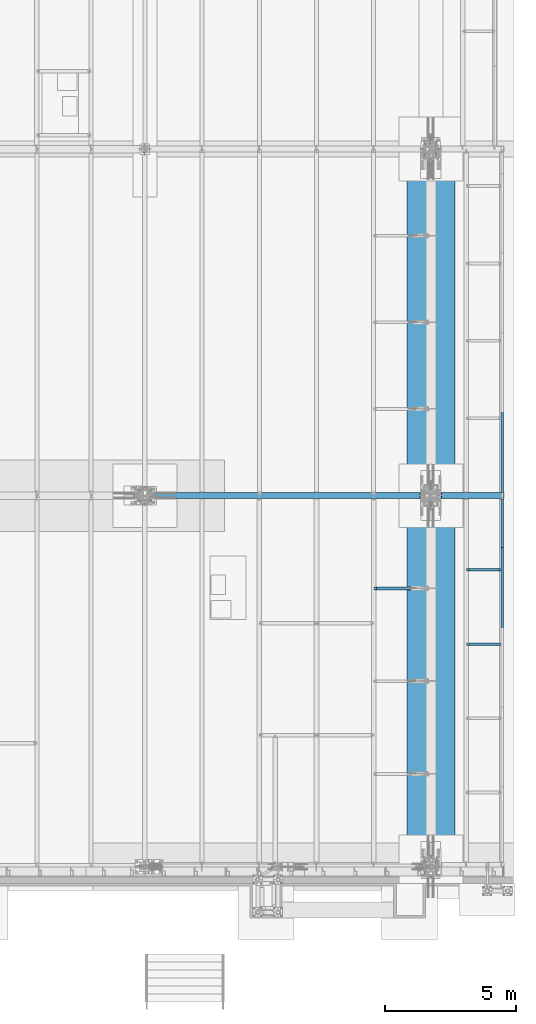
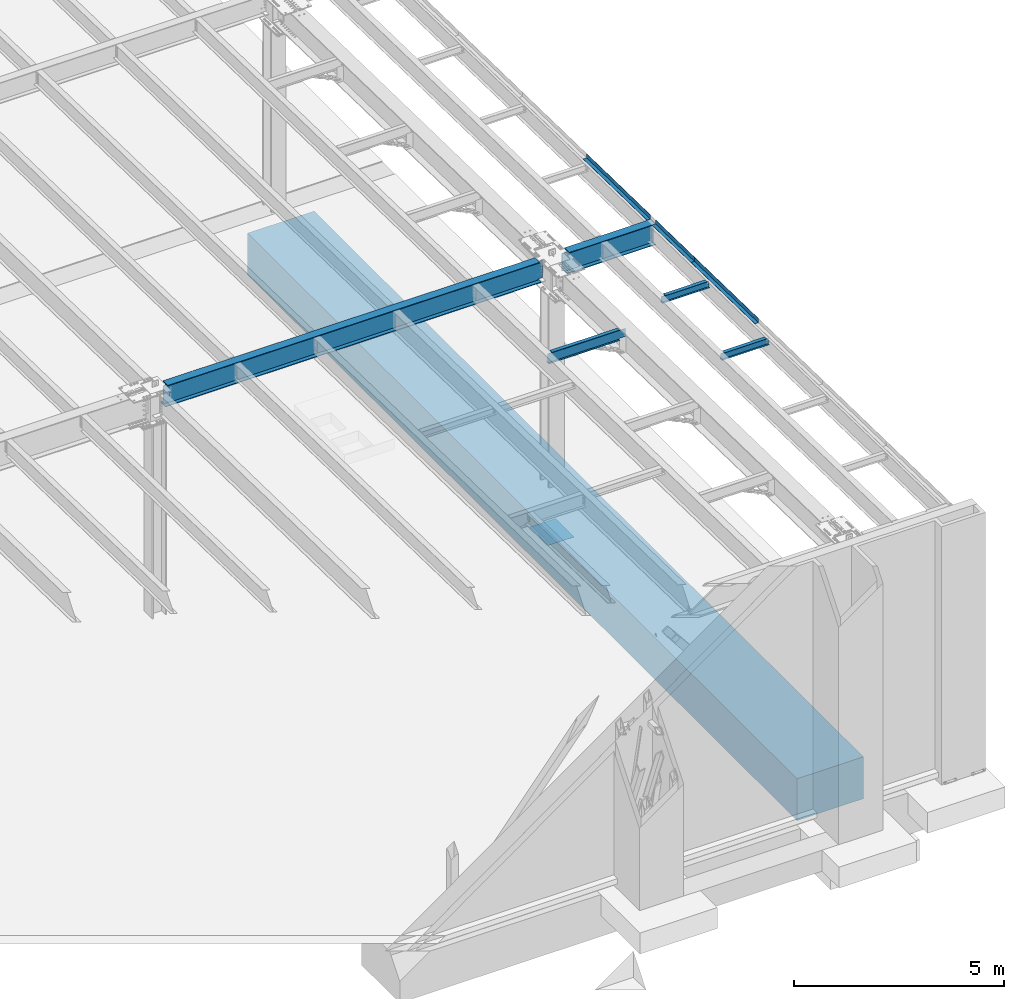
# One storey, part 1114 of 1763: 10 beams, 9 elements without a shape of their own.
"""IFC2X3 building model written with IfcOpenShell, lengths in millimetres."""

from ifc_helpers import new_model, si_unit, frame, origin_with_axes, place, context, subcontext, project, spatial, faceted_brep, material, type_object, element, aggregate, save


model = new_model("IFC2X3")

# Units and contexts
model_context = context("Model", 3, precision=1e-05, world=origin_with_axes())
body_context = subcontext(model_context, "Body", "Model", "MODEL_VIEW")
ifc_project = project(units=[si_unit("LENGTHUNIT", "METRE", prefix="MILLI"), si_unit("AREAUNIT", "SQUARE_METRE"), si_unit("VOLUMEUNIT", "CUBIC_METRE"), si_unit("MASSUNIT", "GRAM", prefix="KILO"), si_unit("TIMEUNIT", "SECOND"), si_unit("PLANEANGLEUNIT", "RADIAN"), si_unit("SOLIDANGLEUNIT", "STERADIAN"), si_unit("THERMODYNAMICTEMPERATUREUNIT", "DEGREE_CELSIUS"), si_unit("LUMINOUSINTENSITYUNIT", "LUMEN")], contexts=[model_context])

# Site, building, storey
site_placement = place(None, origin_with_axes())
site = spatial("IfcSite", under=ifc_project, at=site_placement, CompositionType="ELEMENT")
building_placement = place(site_placement, origin_with_axes())
building = spatial("IfcBuilding", under=site, at=building_placement, Name="Undefined", CompositionType="ELEMENT")
storey_placement = place(building_placement, origin_with_axes())
storey = spatial("IfcBuildingStorey", under=building, at=storey_placement, Name="Undefined", CompositionType="ELEMENT", Elevation=0.0)

# Assembly, beam
assembly_1_placement = place(storey_placement, origin_with_axes())
assembly_1 = element("IfcElementAssembly", 1, at=assembly_1_placement, inside=storey, Name="BEAM", AssemblyPlace="NOTDEFINED", PredefinedType="RIGID_FRAME")
ifc_material_1 = material(Name="STEEL/A36")
beam_type_1 = type_object("IfcBeamType", PredefinedType="NOTDEFINED")
beam_1_placement = place(assembly_1_placement, frame((-21348.1372736983, 2101.56926375685, 11877.1948079628), z_axis=(0.0, -0.999781542838788, 0.0209013539966307), x_axis=(1.0, 0.0, 0.0)))
beam_1 = element("IfcBeam", 2, at=beam_1_placement, type_object=beam_type_1, material=ifc_material_1, Name="BENT_PLATE", context=body_context, shape_type="Brep", body=[
    faceted_brep([(0.0, -3.17499999999927, -1523.99999999999), (0.0, -3.17499999999927, 1524.0), (0.0, 3.17499999999927, 1524.0), (0.0, 3.17499999999927, -1523.99999999999), (95.2499984741262, 3.17499999910251, 1523.99999999978), (95.2499984741262, 3.17500000090149, -1523.99999999977), (101.599998474125, -3.17499999909887, -1523.99999999978), (101.599999809252, -3.17500000000655, 1524.0), (95.2499984741262, 123.825003587437, 1523.99999999985), (95.2499984741262, 123.825003589236, -1523.9999999997), (101.599998474125, 123.825003587437, 1523.99999999985), (101.599998474125, 123.825003589236, -1523.9999999997)], [[[0, 1, 2, 3]], [[3, 2, 4, 5]], [[1, 0, 6, 7]], [[5, 4, 8, 9]], [[4, 2, 1, 7, 10, 8]], [[7, 6, 11, 10]], [[6, 0, 3, 5, 9, 11]], [[10, 11, 9, 8]]]),
])
aggregate(assembly_1, [beam_1])

# Assembly, beams
assembly_2_placement = place(storey_placement, origin_with_axes())
assembly_2 = element("IfcElementAssembly", 3, at=assembly_2_placement, inside=storey, Name="BEAM", AssemblyPlace="NOTDEFINED", PredefinedType="RIGID_FRAME")
beam_2_placement = place(assembly_2_placement, frame((-21348.1372736984, -595.183817089988, 11933.5729215789), z_axis=(0.0, -0.999781542838788, 0.0209013539966307), x_axis=(1.0, 0.0, 0.0)))
beam_2 = element("IfcBeam", 4, at=beam_2_placement, type_object=beam_type_1, material=ifc_material_1, Name="BENT_PLATE", context=body_context, shape_type="Brep", body=[
    faceted_brep([(7.71251507103443e-10, -3.17500000032305, -931.072000000008), (-6.47560227662325e-10, -3.17499999968095, 931.072000000008), (-7.71251507103443e-10, 3.17500000032487, 931.072000000008), (6.47560227662325e-10, 3.17499999968277, -931.072000000007), (95.2499984735041, 3.17500000219843, 931.07200000008), (95.2499984760543, 3.17500000155633, -931.071999999935), (101.599998476056, -3.1749999983258, -931.07199999993), (101.599998473506, -3.17499999768188, 931.072000000085), (95.2499984740389, 123.825003584232, 931.072000000157), (95.2499984755195, 123.825003584727, -931.071999999858), (101.599998474041, 123.82500358423, 931.072000000162), (101.599998475522, 123.825003584727, -931.071999999853)], [[[0, 1, 2, 3]], [[3, 2, 4, 5]], [[1, 0, 6, 7]], [[5, 4, 8, 9]], [[4, 2, 1, 7, 10, 8]], [[7, 6, 11, 10]], [[6, 0, 3, 5, 9, 11]], [[10, 11, 9, 8]]]),
])
beam_3_placement = place(assembly_2_placement, frame((-21348.1372736984, -3049.71948893012, 11984.887255447), z_axis=(0.0, -0.999781542838788, 0.0209013539966307), x_axis=(1.0, 0.0, 0.0)))
beam_3 = element("IfcBeam", 5, at=beam_3_placement, type_object=beam_type_1, material=ifc_material_1, Name="BENT_PLATE", context=body_context, shape_type="Brep", body=[
    faceted_brep([(0.0, -3.17499999999927, -1523.99999999999), (0.0, -3.17499999999927, 1524.0), (0.0, 3.17499999999927, 1524.0), (0.0, 3.17499999999927, -1523.99999999999), (95.2499984741262, 3.17499999910251, 1523.99999999978), (95.2499984741262, 3.17500000090149, -1523.99999999977), (101.599998474125, -3.17499999909887, -1523.99999999978), (101.599999809252, -3.17500000000655, 1524.0), (95.2499984741262, 123.825003587437, 1523.99999999985), (95.2499984741262, 123.825003589236, -1523.9999999997), (101.599998474125, 123.825003587437, 1523.99999999985), (101.599998474125, 123.825003589236, -1523.9999999997)], [[[0, 1, 2, 3]], [[3, 2, 4, 5]], [[1, 0, 6, 7]], [[5, 4, 8, 9]], [[4, 2, 1, 7, 10, 8]], [[7, 6, 11, 10]], [[6, 0, 3, 5, 9, 11]], [[10, 11, 9, 8]]]),
])
aggregate(assembly_2, [beam_2, beam_3])

# Assembly, beam
assembly_3_placement = place(storey_placement, origin_with_axes())
assembly_3 = element("IfcElementAssembly", 6, at=assembly_3_placement, inside=storey, Name="BEAM", AssemblyPlace="NOTDEFINED", PredefinedType="RIGID_FRAME")
ifc_material_2 = material(Name="STEEL/A992")
beam_type_2 = type_object("IfcBeamType", Name="W8X10", PredefinedType="NOTDEFINED")
beam_4_placement = place(assembly_3_placement, frame((-22678.4622736984, -5212.08, 11926.905204137), z_axis=(0.0, 0.0, 1.0), x_axis=(1.0, 0.0, 0.0)))
beam_4 = element("IfcBeam", 7, at=beam_4_placement, type_object=beam_type_2, material=ifc_material_2, Name="BEAM", ObjectType="W8X10", context=body_context, shape_type="Brep", body=[
    faceted_brep([(1249.3625, -50.7999999999993, 100.012500000001), (1249.3625, -50.7999999999993, 95.25), (1249.3625, -2.38125000000036, 95.25), (1249.3625, -2.38125000000036, 87.0525014841896), (1249.3625, 2.38125000000036, 87.0525014841896), (1249.3625, 2.38125000000036, 95.25), (1249.3625, 50.7999999999993, 95.25), (1249.3625, 50.7999999999993, 100.012500000001), (1250.32922992258, -2.38125000000036, 82.1924219661432), (1250.32922992258, 2.38125000000036, 82.1924219661432), (1253.08224382306, -2.38125000000036, 78.0722454979896), (1253.08224382306, 2.38125000000036, 78.0722454979896), (1257.20242029121, -2.38125000000036, 75.319231597512), (1257.20242029121, 2.38125000000036, 75.319231597512), (1262.06249980926, -2.38125000000036, 74.3525016749245), (1262.06249980926, 2.38125000000036, 74.3525016749245), (1331.91249999999, -2.38125000000036, 74.3525016749245), (1331.91249999999, 2.38125000000036, 74.3525016749245), (100.012500000012, -50.7999999999993, 100.012500000001), (100.012500000012, 50.7999999999993, 100.012500000001), (100.012500000012, 50.7999999999993, 95.25), (100.012500000012, 2.38124999999854, 95.25), (100.012499999993, 2.38125000000036, 87.0525014841896), (100.012499999993, -2.38125000000036, 87.0525014841896), (100.012500000012, -2.38124999999854, 95.25), (100.012500000012, -50.7999999999993, 95.25), (99.0457700774059, 2.38125000000036, 82.1924219661432), (99.0457700774059, -2.38125000000036, 82.1924219661432), (96.2927561769284, 2.38125000000036, 78.0722454979896), (96.2927561769284, -2.38125000000036, 78.0722454979896), (92.1725797087747, 2.38125000000036, 75.319231597512), (92.1725797087747, -2.38125000000036, 75.319231597512), (87.3125001907283, 2.38125000000036, 74.3525016749245), (87.3125001907283, -2.38125000000036, 74.3525016749245), (17.4624999999978, 2.38125000000036, 74.3525016749245), (17.4624999999978, -2.38125000000036, 74.3525016749245), (17.462499935149, 2.38124999999854, -95.25), (17.4625000000015, 50.7999999999993, -95.25), (17.4625000000015, 50.7999999999993, -100.012500000001), (17.4624996160601, -50.8000000000029, -100.012500000001), (17.4624996160601, -50.8000000000029, -95.25), (17.4624999065727, -2.38124999999854, -95.25), (1331.91249999999, 2.38125000000036, -95.25), (1331.91249999999, 50.7999999999993, -95.25), (1331.91249999999, 50.7999999999993, -100.012500000001), (1331.91249999999, -50.7999999999993, -100.012500000001), (1331.91249999999, -50.7999999999993, -95.25), (1331.91249999999, -2.38125000000036, -95.25)], [[[0, 1, 2, 3, 4, 5, 6, 7]], [[8, 9, 4, 3]], [[10, 11, 9, 8]], [[12, 13, 11, 10]], [[14, 15, 13, 12]], [[16, 17, 15, 14]], [[18, 19, 20, 21, 22, 23, 24, 25]], [[23, 22, 26, 27]], [[27, 26, 28, 29]], [[29, 28, 30, 31]], [[31, 30, 32, 33]], [[33, 32, 34, 35]], [[36, 37, 38, 39, 40, 41, 35, 34]], [[37, 36, 42, 43]], [[38, 37, 43, 44]], [[39, 38, 44, 45]], [[40, 39, 45, 46]], [[41, 40, 46, 47]], [[12, 10, 8, 3, 2, 24, 23, 27, 29, 31, 33, 35, 41, 47, 16, 14]], [[25, 24, 2, 1]], [[18, 25, 1, 0]], [[19, 18, 0, 7]], [[20, 19, 7, 6]], [[21, 20, 6, 5]], [[42, 36, 34, 32, 30, 28, 26, 22, 21, 5, 4, 9, 11, 13, 15, 17]], [[47, 46, 45, 44, 43, 42, 17, 16]]]),
])
aggregate(assembly_3, [beam_4])

assembly_4_placement = place(storey_placement, origin_with_axes())
assembly_4 = element("IfcElementAssembly", 8, at=assembly_4_placement, inside=storey, Name="BEAM", AssemblyPlace="NOTDEFINED", PredefinedType="RIGID_FRAME")
beam_5_placement = place(assembly_4_placement, frame((-22678.4622736984, -2377.44, 11867.6444384361), z_axis=(0.0, 0.0, 1.0), x_axis=(1.0, 0.0, 0.0)))
beam_5 = element("IfcBeam", 9, at=beam_5_placement, type_object=beam_type_2, material=ifc_material_2, Name="BEAM", ObjectType="W8X10", context=body_context, shape_type="Brep", body=[
    faceted_brep([(1249.3625, -50.7999999999993, 100.012500000001), (1249.3625, -50.7999999999993, 95.25), (1249.3625, -2.38125000000036, 95.25), (1249.3625, -2.38125000000036, 87.0525014841896), (1249.3625, 2.38125000000036, 87.0525014841896), (1249.3625, 2.38125000000036, 95.25), (1249.3625, 50.7999999999993, 95.25), (1249.3625, 50.7999999999993, 100.012500000001), (1250.32922992258, -2.38125000000036, 82.1924219661432), (1250.32922992258, 2.38125000000036, 82.1924219661432), (1253.08224382306, -2.38125000000036, 78.0722454979896), (1253.08224382306, 2.38125000000036, 78.0722454979896), (1257.20242029121, -2.38125000000036, 75.319231597512), (1257.20242029121, 2.38125000000036, 75.319231597512), (1262.06249980926, -2.38125000000036, 74.3525016749245), (1262.06249980926, 2.38125000000036, 74.3525016749245), (1331.91249999999, -2.38125000000036, 74.3525016749245), (1331.91249999999, 2.38125000000036, 74.3525016749245), (100.012500000012, -50.7999999999993, 100.012500000001), (100.012500000012, 50.7999999999993, 100.012500000001), (100.012500000012, 50.7999999999993, 95.25), (100.012500000012, 2.38124999999854, 95.25), (100.012499999993, 2.38125000000036, 87.0525014841896), (100.012499999993, -2.38125000000036, 87.0525014841896), (100.012500000012, -2.38124999999854, 95.25), (100.012500000012, -50.7999999999993, 95.25), (99.0457700774059, 2.38125000000036, 82.1924219661432), (99.0457700774059, -2.38125000000036, 82.1924219661432), (96.2927561769284, 2.38125000000036, 78.0722454979896), (96.2927561769284, -2.38125000000036, 78.0722454979896), (92.1725797087747, 2.38125000000036, 75.319231597512), (92.1725797087747, -2.38125000000036, 75.319231597512), (87.3125001907283, 2.38125000000036, 74.3525016749245), (87.3125001907283, -2.38125000000036, 74.3525016749245), (17.4624999999978, 2.38125000000036, 74.3525016749245), (17.4624999999978, -2.38125000000036, 74.3525016749245), (17.462499935149, 2.38124999999854, -95.25), (17.4625000000015, 50.7999999999993, -95.25), (17.4625000000015, 50.7999999999993, -100.012500000001), (17.4624996160601, -50.8000000000029, -100.012500000001), (17.4624996160601, -50.8000000000029, -95.25), (17.4624999065727, -2.38124999999854, -95.25), (1331.91249999999, 2.38125000000036, -95.25), (1331.91249999999, 50.7999999999993, -95.25), (1331.91249999999, 50.7999999999993, -100.012500000001), (1331.91249999999, -50.7999999999993, -100.012500000001), (1331.91249999999, -50.7999999999993, -95.25), (1331.91249999999, -2.38125000000036, -95.25)], [[[0, 1, 2, 3, 4, 5, 6, 7]], [[8, 9, 4, 3]], [[10, 11, 9, 8]], [[12, 13, 11, 10]], [[14, 15, 13, 12]], [[16, 17, 15, 14]], [[18, 19, 20, 21, 22, 23, 24, 25]], [[23, 22, 26, 27]], [[27, 26, 28, 29]], [[29, 28, 30, 31]], [[31, 30, 32, 33]], [[33, 32, 34, 35]], [[36, 37, 38, 39, 40, 41, 35, 34]], [[37, 36, 42, 43]], [[38, 37, 43, 44]], [[39, 38, 44, 45]], [[40, 39, 45, 46]], [[41, 40, 46, 47]], [[12, 10, 8, 3, 2, 24, 23, 27, 29, 31, 33, 35, 41, 47, 16, 14]], [[25, 24, 2, 1]], [[18, 25, 1, 0]], [[19, 18, 0, 7]], [[20, 19, 7, 6]], [[21, 20, 6, 5]], [[42, 36, 34, 32, 30, 28, 26, 22, 21, 5, 4, 9, 11, 13, 15, 17]], [[47, 46, 45, 44, 43, 42, 17, 16]]]),
])
aggregate(assembly_4, [beam_5])

assembly_5_placement = place(storey_placement, origin_with_axes())
assembly_5 = element("IfcElementAssembly", 10, at=assembly_5_placement, inside=storey, Name="BEAM", AssemblyPlace="NOTDEFINED", PredefinedType="RIGID_FRAME")
beam_type_3 = type_object("IfcBeamType", Name="W12X22", PredefinedType="NOTDEFINED")
beam_6_placement = place(assembly_5_placement, frame((-26212.2372736983, -3086.11074964898, 11826.8973545926), z_axis=(0.0, 0.0, 1.0), x_axis=(1.0, 0.0, 0.0)))
beam_6 = element("IfcBeam", 11, at=beam_6_placement, type_object=beam_type_3, material=ifc_material_2, Name="BEAM", ObjectType="W12X22", context=body_context, shape_type="Brep", body=[
    faceted_brep([(1973.26249999999, -3.17499999999927, -144.4625), (1973.26249999999, -50.7999999999993, -144.4625), (1973.26249999999, -50.7999999999993, -155.575000000001), (1973.26249999999, 50.7999999999993, -155.575000000001), (1973.26249999999, 50.7999999999993, -144.4625), (1973.26249999999, 3.17499999999927, -144.4625), (1973.26249999999, 3.17499999999927, -136.524999809046), (1973.26249999999, -3.17499999999927, -136.524999809046), (1974.22922992258, 3.17499999999927, -131.664920290999), (1974.22922992258, -3.17499999999927, -131.664920290999), (1976.98224382305, 3.17499999999927, -127.544743822846), (1976.98224382305, -3.17499999999927, -127.544743822846), (1981.10242029121, 3.17499999999927, -124.791729922368), (1981.10242029121, -3.17499999999927, -124.791729922368), (1985.96249980925, 3.17499999999927, -123.824999999781), (1985.96249980925, -3.17499999999927, -123.824999999781), (2163.76249999999, -3.17499999999927, -123.824999999781), (2163.76249999999, 3.17499999999927, -123.824999999781), (106.362499999999, 3.17500000000018, 144.4625), (106.362499999999, 50.8000000000002, 144.4625), (1973.26249999999, 50.7999999999993, 144.4625), (1973.26249999999, 3.17499999999927, 144.4625), (17.4624999999978, 3.17500000000018, -144.4625), (17.4624999999978, 50.8000000000002, -144.4625), (17.4624999999978, 50.8000000000002, -155.575000000001), (17.4624999999978, -50.8000000000002, -155.575000000001), (17.4624999999978, -50.8000000000002, -144.4625), (17.4624999999978, -3.17500000000018, -144.4625), (17.4624999999978, -3.17500000000018, 117.215001688795), (17.4624999999978, 3.17500000000018, 117.215001688795), (93.6625001907341, -3.17500000000018, 117.215001688795), (93.6625001907341, 3.17500000000018, 117.215001688795), (98.5225797087805, -3.17500000000018, 118.181731611383), (98.5225797087805, 3.17500000000018, 118.181731611383), (102.642756176934, -3.17500000000018, 120.93474551186), (102.642756176934, 3.17500000000018, 120.93474551186), (105.395770077412, -3.17500000000018, 125.054921980014), (105.395770077412, 3.17500000000018, 125.054921980014), (106.362499999999, -3.17500000000018, 129.915001498061), (106.362499999999, 3.17500000000018, 129.915001498061), (106.362499999999, -50.8000000000002, 155.575000000001), (106.362499999999, 50.8000000000002, 155.575000000001), (106.362499999999, -3.17500000000018, 144.4625), (106.362499999999, -50.8000000000002, 144.4625), (1973.26249999999, -3.17499999999927, 144.4625), (1973.26249999999, -50.7999999999993, 144.4625), (1973.26249999999, -50.7999999999993, 155.575000000001), (1973.26249999999, 50.7999999999993, 155.575000000001), (1973.26249999999, -3.17499999999927, 123.824999809485), (1973.26249999999, 3.17499999999927, 123.824999809485), (1974.22922992258, -3.17499999999927, 118.964920291439), (1974.22922992258, 3.17499999999927, 118.964920291439), (1976.98224382305, -3.17499999999927, 114.844743823285), (1976.98224382305, 3.17499999999927, 114.844743823285), (1981.10242029121, -3.17499999999927, 112.091729922808), (1981.10242029121, 3.17499999999927, 112.091729922808), (1985.96249980925, -3.17499999999927, 111.12500000022), (1985.96249980925, 3.17499999999927, 111.12500000022), (2163.76249999999, -3.17499999999927, 111.12500000022), (2163.76249999999, 3.17499999999927, 111.12500000022)], [[[0, 1, 2, 3, 4, 5, 6, 7]], [[7, 6, 8, 9]], [[9, 8, 10, 11]], [[11, 10, 12, 13]], [[13, 12, 14, 15]], [[16, 15, 14, 17]], [[18, 19, 20, 21]], [[22, 23, 24, 25, 26, 27, 28, 29]], [[30, 31, 29, 28]], [[32, 33, 31, 30]], [[34, 35, 33, 32]], [[36, 37, 35, 34]], [[38, 39, 37, 36]], [[40, 41, 19, 18, 39, 38, 42, 43]], [[43, 42, 44, 45]], [[40, 43, 45, 46]], [[41, 40, 46, 47]], [[19, 41, 47, 20]], [[46, 45, 44, 48, 49, 21, 20, 47]], [[50, 51, 49, 48]], [[52, 53, 51, 50]], [[54, 55, 53, 52]], [[56, 57, 55, 54]], [[58, 59, 57, 56]], [[59, 58, 16, 17]], [[12, 10, 8, 6, 5, 22, 29, 31, 33, 35, 37, 39, 18, 21, 49, 51, 53, 55, 57, 59, 17, 14]], [[23, 22, 5, 4]], [[24, 23, 4, 3]], [[25, 24, 3, 2]], [[26, 25, 2, 1]], [[27, 26, 1, 0]], [[58, 56, 54, 52, 50, 48, 44, 42, 38, 36, 34, 32, 30, 28, 27, 0, 7, 9, 11, 13, 15, 16]]]),
])
aggregate(assembly_5, [beam_6])

assembly_6_placement = place(storey_placement, origin_with_axes())
assembly_6 = element("IfcElementAssembly", 12, at=assembly_6_placement, inside=storey, Name="BEAM", AssemblyPlace="NOTDEFINED", PredefinedType="RIGID_FRAME")
beam_type_4 = type_object("IfcBeamType", Name="W24X76", PredefinedType="NOTDEFINED")
beam_7_placement = place(assembly_6_placement, frame((-34949.8372736984, 457.200000000001, 11605.1836714953), z_axis=(0.0, 0.0, 1.0), x_axis=(1.0, 0.0, 0.0)))
beam_7 = element("IfcBeam", 13, at=beam_7_placement, type_object=beam_type_4, material=ifc_material_2, Name="BEAM", ObjectType="W24X76", context=body_context, shape_type="Brep", body=[
    faceted_brep([(212.725000000348, 114.3, -303.2125), (212.725000000348, 114.3, -285.75), (10564.2558844608, 114.3, -285.75), (10574.3371204082, 114.3, -303.2125), (212.725000000348, 5.55624999999998, -285.75), (10564.2558844608, 5.55624999999998, -285.75), (276.225000000355, 114.3, 285.75), (276.225000000355, 114.3, 303.2125), (10513.4559067116, 114.3, 303.2125), (10523.5375203042, 114.3, 285.75), (276.225000000355, 5.55624999999998, 285.75), (10523.5375203042, 5.55624999999998, 285.75), (276.225000000355, -114.3, 303.2125), (276.225000000355, 5.55624999999998, 264.85250148773), (276.225000000355, -5.55624999999998, 264.85250148773), (276.225000000355, -5.55624999999998, 285.75), (276.225000000355, -114.3, 285.75), (275.258270077764, 5.55624999999998, 259.992421969684), (275.258270077764, -5.55624999999998, 259.992421969684), (272.50525617729, 5.55624999999998, 255.87224550153), (272.50525617729, -5.55624999999998, 255.87224550153), (268.385079709136, 5.55624999999998, 253.119231601053), (268.385079709136, -5.55624999999998, 253.119231601053), (263.52500019109, 5.55624999999998, 252.152501678465), (263.52500019109, -5.55624999999998, 252.152501678465), (10544.7475016174, 5.55624999999998, -285.352999496459), (10544.7475016174, -5.55624999999998, -285.352999496459), (10564.0266930078, -5.55624999999998, -285.352999496459), (10564.0266930078, 5.55624999999998, -285.352999496459), (10524.9963461621, 5.55624999999998, -275.165223187232), (10524.9963461621, -5.55624999999998, -275.165223187232), (10521.3002965394, 5.55624999999998, -271.771708479522), (10521.3002965394, -5.55624999999998, -271.771708479522), (10519.8416142521, 5.55624999999998, -266.970774104921), (10519.8416142521, -5.55624999999998, -266.970774104921), (10521.0250895187, 5.55624999999998, -262.094698718112), (10521.0250895187, -5.55624999999998, -262.094698718112), (10524.5223031791, 5.55624999999998, -258.496612907766), (10524.5223031791, -5.55624999999998, -258.496612907766), (10529.3627643355, 5.55624999999998, -257.174999999999), (10529.3627643355, -5.55624999999998, -257.174999999999), (10656.8875, 5.55624999999998, -257.174999999999), (10656.8875, -5.55624999999998, -257.174999999999), (10656.8875, -5.55624999999998, 257.174999999999), (10656.8875, 5.55624999999998, 257.174999999999), (10481.1647575055, 5.55624999999998, 257.174999999999), (10481.1647575055, -5.55624999999998, 257.174999999999), (10476.3242963957, 5.55624999999998, 258.496612880223), (10476.3242963957, -5.55624999999998, 258.496612880223), (10472.8270827411, 5.55624999999998, 262.094698623232), (10472.8270827411, -5.55624999999998, 262.094698623232), (10471.6436074174, 5.55624999999998, 266.970773942399), (10471.6436074174, -5.55624999999998, 266.970773942399), (10473.102289594, 5.55624999999998, 271.771708296024), (10473.102289594, -5.55624999999998, 271.771708296024), (10476.7983390912, 5.55624999999998, 275.165223063012), (10476.7983390912, -5.55624999999998, 275.165223063012), (10496.5494934082, 5.55624999999998, 285.352999496459), (10496.5494934082, -5.55624999999998, 285.352999496459), (10523.7667203427, 5.55624999999998, 285.352999496459), (10523.7667203427, -5.55624999999998, 285.352999496459), (212.725000000348, -5.55624999999998, 252.152501678465), (212.725000000348, -5.55624999999998, -285.44999923706), (212.725000000348, -5.55624999999998, -285.75), (10564.2558844608, -5.55624999999998, -285.75), (10523.5375203042, -5.55624999999998, 285.75), (10523.5375203042, -114.3, 285.75), (10513.4559067116, -114.3, 303.2125), (212.725000000348, 5.55624999999998, -285.44999923706), (212.725000000348, 5.55624999999998, 252.152501678465), (212.725000000348, -114.3, -303.2125), (212.725000000348, -114.3, -285.75), (10574.3371204082, -114.3, -303.2125), (10564.2558844608, -114.3, -285.75)], [[[0, 1, 2, 3]], [[1, 4, 5, 2]], [[6, 7, 8, 9]], [[10, 6, 9, 11]], [[12, 7, 6, 10, 13, 14, 15, 16]], [[14, 13, 17, 18]], [[18, 17, 19, 20]], [[20, 19, 21, 22]], [[22, 21, 23, 24]], [[25, 26, 27, 28]], [[26, 25, 29, 30]], [[30, 29, 31, 32]], [[32, 31, 33, 34]], [[34, 33, 35, 36]], [[36, 35, 37, 38]], [[38, 37, 39, 40]], [[40, 39, 41, 42]], [[43, 42, 41, 44]], [[45, 46, 43, 44]], [[46, 45, 47, 48]], [[48, 47, 49, 50]], [[50, 49, 51, 52]], [[52, 51, 53, 54]], [[54, 53, 55, 56]], [[56, 55, 57, 58]], [[58, 57, 59, 60]], [[15, 14, 18, 20, 22, 24, 61, 62, 63, 64, 27, 26, 30, 32, 34, 36, 38, 40, 42, 43, 46, 48, 50, 52, 54, 56, 58, 60, 65]], [[16, 15, 65, 66]], [[12, 16, 66, 67]], [[7, 12, 67, 8]], [[66, 65, 60, 59, 11, 9, 8, 67]], [[57, 55, 53, 51, 49, 47, 45, 44, 41, 39, 37, 35, 33, 31, 29, 25, 28, 5, 4, 68, 69, 23, 21, 19, 17, 13, 10, 11, 59]], [[24, 23, 69, 61]], [[68, 4, 1, 0, 70, 71, 63, 62, 61, 69]], [[71, 70, 72, 73]], [[63, 71, 73, 64]], [[72, 3, 2, 5, 28, 27, 64, 73]], [[70, 0, 3, 72]]]),
])
aggregate(assembly_6, [beam_7])

assembly_7_placement = place(storey_placement, origin_with_axes())
assembly_7 = element("IfcElementAssembly", 14, at=assembly_7_placement, inside=storey, Name="BEAM", AssemblyPlace="NOTDEFINED", PredefinedType="RIGID_FRAME")
beam_8_placement = place(assembly_7_placement, frame((-24027.8372736983, 457.200000000003, 11605.1836714953), z_axis=(0.0, 0.0, 1.0), x_axis=(1.0, 0.0, 0.0)))
beam_8 = element("IfcBeam", 15, at=beam_8_placement, type_object=beam_type_4, material=ifc_material_2, Name="BEAM", ObjectType="W24X76", context=body_context, shape_type="Brep", body=[
    faceted_brep([(408.54409328835, -114.3, 303.2125), (408.54409328835, 114.3, 303.2125), (398.462479695812, 114.3, 285.75), (398.462479695812, 5.55624999999998, 285.75), (398.233279657285, 5.55624999999998, 285.352999496459), (398.233279657285, -5.55624999999998, 285.352999496459), (398.462479695812, -5.55624999999998, 285.75), (398.462479695812, -114.3, 285.75), (425.45050659178, -5.55624999999998, 285.352999496459), (425.45050659178, 5.55624999999998, 285.352999496459), (445.201660908737, 5.55624999999998, 275.165223063008), (445.201660908737, -5.55624999999998, 275.165223063008), (448.897710406, 5.55624999999998, 271.771708296021), (448.897710406, -5.55624999999998, 271.771708296021), (450.356392582537, 5.55624999999998, 266.970773942396), (450.356392582537, -5.55624999999998, 266.970773942396), (449.172917258849, 5.55624999999998, 262.094698623228), (449.172917258849, -5.55624999999998, 262.094698623228), (445.675703604251, 5.55624999999998, 258.496612880219), (445.675703604251, -5.55624999999998, 258.496612880219), (440.835242494519, 5.55624999999998, 257.174999999996), (440.835242494519, -5.55624999999998, 257.174999999996), (265.112499999981, 5.55624999999998, 257.174999999999), (265.112499999981, -5.55624999999998, 257.174999999999), (265.112499999981, 5.55624999999998, -257.174999999999), (265.112499999981, -5.55624999999998, -257.174999999999), (392.637235664493, 5.55624999999998, -257.174999999999), (392.637235664493, -5.55624999999998, -257.174999999999), (397.477696820897, 5.55624999999998, -258.496612907766), (397.477696820897, -5.55624999999998, -258.496612907766), (400.974910481229, 5.55624999999998, -262.094698718112), (400.974910481229, -5.55624999999998, -262.094698718112), (402.158385747887, 5.55624999999998, -266.970774104921), (402.158385747887, -5.55624999999998, -266.970774104921), (400.699703460541, 5.55624999999998, -271.771708479522), (400.699703460541, -5.55624999999998, -271.771708479522), (397.003653837881, 5.55624999999998, -275.165223187232), (397.003653837881, -5.55624999999998, -275.165223187232), (377.25249838255, 5.55624999999998, -285.352999496459), (377.25249838255, -5.55624999999998, -285.352999496459), (357.973306992182, 5.55624999999998, -285.352999496459), (357.973306992182, -5.55624999999998, -285.352999496459), (2794.00468749999, 5.55624999999998, -285.75), (2794.00468749999, 114.3, -285.75), (357.744115539215, 114.3, -285.75), (357.744115539215, 5.55624999999998, -285.75), (2794.00468749999, 114.3, -303.2125), (2794.00468749999, -114.3, -303.2125), (347.662879591775, -114.3, -303.2125), (347.662879591775, 114.3, -303.2125), (2794.00468749999, -114.3, -285.75), (357.744115539215, -114.3, -285.75), (2794.00468749999, -5.55624999999998, -285.75), (357.744115539215, -5.55624999999998, -285.75), (2794.00468749999, 5.55624999999998, 285.75), (2794.00468749999, 114.3, 285.75), (2794.00468749999, 114.3, 303.2125), (2794.00468749999, -114.3, 303.2125), (2794.00468749999, -114.3, 285.75), (2794.00468749999, -5.55624999999998, 285.75)], [[[0, 1, 2, 3, 4, 5, 6, 7]], [[8, 9, 10, 11]], [[11, 10, 12, 13]], [[13, 12, 14, 15]], [[15, 14, 16, 17]], [[17, 16, 18, 19]], [[19, 18, 20, 21]], [[21, 20, 22, 23]], [[23, 22, 24, 25]], [[26, 27, 25, 24]], [[27, 26, 28, 29]], [[29, 28, 30, 31]], [[31, 30, 32, 33]], [[33, 32, 34, 35]], [[35, 34, 36, 37]], [[37, 36, 38, 39]], [[39, 38, 40, 41]], [[42, 43, 44, 45]], [[46, 47, 48, 49]], [[47, 50, 51, 48]], [[50, 52, 53, 51]], [[41, 40, 45, 44, 49, 48, 51, 53]], [[43, 46, 49, 44]], [[42, 54, 55, 56, 57, 58, 59, 52, 50, 47, 46, 43]], [[58, 57, 0, 7]], [[59, 58, 7, 6]], [[8, 11, 13, 15, 17, 19, 21, 23, 25, 27, 29, 31, 33, 35, 37, 39, 41, 53, 52, 59, 6, 5]], [[9, 8, 5, 4]], [[54, 42, 45, 40, 38, 36, 34, 32, 30, 28, 26, 24, 22, 20, 18, 16, 14, 12, 10, 9, 4, 3]], [[55, 54, 3, 2]], [[56, 55, 2, 1]], [[57, 56, 1, 0]]]),
])
aggregate(assembly_7, [beam_8])

assembly_8_placement = place(storey_placement, origin_with_axes())
assembly_8 = element("IfcElementAssembly", 16, at=assembly_8_placement, inside=storey, Name="TEMPLATE", AssemblyPlace="NOTDEFINED", PredefinedType="RIGID_FRAME")
beam_type_5 = type_object("IfcBeamType", PredefinedType="NOTDEFINED")
beam_9_placement = place(assembly_8_placement, frame((-24027.8372736984, 12.6999999999981, 3851.275), z_axis=(-1.0, 0.0, 0.0), x_axis=(0.0, 1.0, 0.0)))
beam_9 = element("IfcBeam", 17, at=beam_9_placement, type_object=beam_type_5, material=ifc_material_1, Name="TEMPLATE", context=body_context, shape_type="Brep", body=[
    faceted_brep([(0.0, 3.17500000000018, -355.599999999999), (0.0, 3.17500000000018, 355.599999999999), (889.0, 3.17500000000018, 355.599999999999), (889.0, 3.17500000000018, -355.599999999999), (0.0, -3.17500000000018, 355.599999999999), (889.0, -3.17500000000018, 355.599999999999), (0.0, -3.17500000000018, -355.599999999999), (889.0, -3.17500000000018, -355.599999999999)], [[[0, 1, 2, 3]], [[1, 4, 5, 2]], [[4, 6, 7, 5]], [[6, 0, 3, 7]], [[5, 7, 3, 2]], [[6, 4, 1, 0]]]),
])
aggregate(assembly_8, [beam_9])

assembly_9_placement = place(storey_placement, origin_with_axes())
assembly_9 = element("IfcElementAssembly", 18, at=assembly_9_placement, inside=storey, Name="STRIP FOOTING", AssemblyPlace="NOTDEFINED", PredefinedType="REINFORCEMENT_UNIT")
ifc_material_3 = material(Name="CONCRETE/5000")
beam_type_6 = type_object("IfcBeamType", PredefinedType="NOTDEFINED")
beam_10_placement = place(assembly_9_placement, frame((-24027.8372736984, -12801.6, 4419.6), z_axis=(0.0, 0.0, 1.0), x_axis=(0.0, 1.0, 0.0)))
beam_10 = element("IfcBeam", 19, at=beam_10_placement, type_object=beam_type_6, material=ifc_material_3, Name="STRIP FOOTING", context=body_context, shape_type="Brep", body=[
    faceted_brep([(0.0, 914.400000000001, -609.6), (0.0, 914.400000000001, 609.6), (26187.4, 914.400000000001, 609.6), (26187.4, 914.400000000001, -609.6), (0.0, -914.400000000001, 609.6), (26187.4, -914.400000000001, 609.6), (0.0, -914.400000000001, -609.6), (26187.4, -914.400000000001, -609.6)], [[[0, 1, 2, 3]], [[1, 4, 5, 2]], [[4, 6, 7, 5]], [[6, 0, 3, 7]], [[5, 7, 3, 2]], [[6, 4, 1, 0]]]),
])
aggregate(assembly_9, [beam_10])

save(model, "model.ifc")
